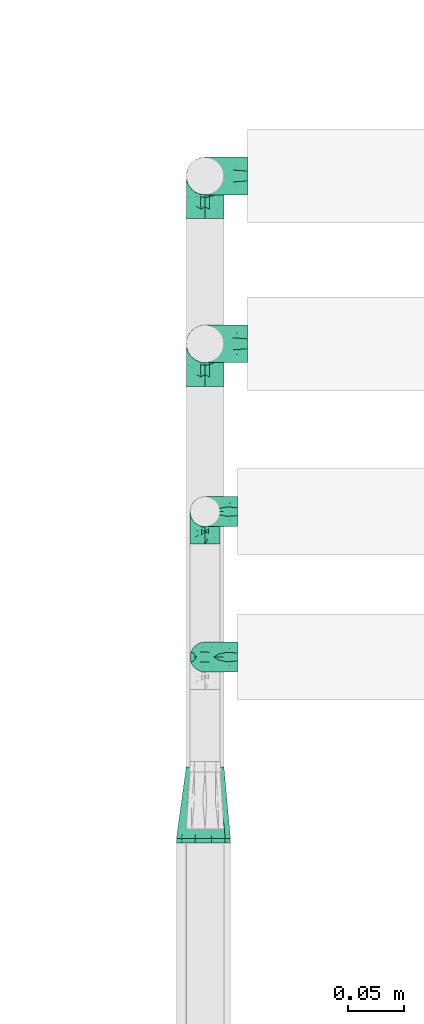
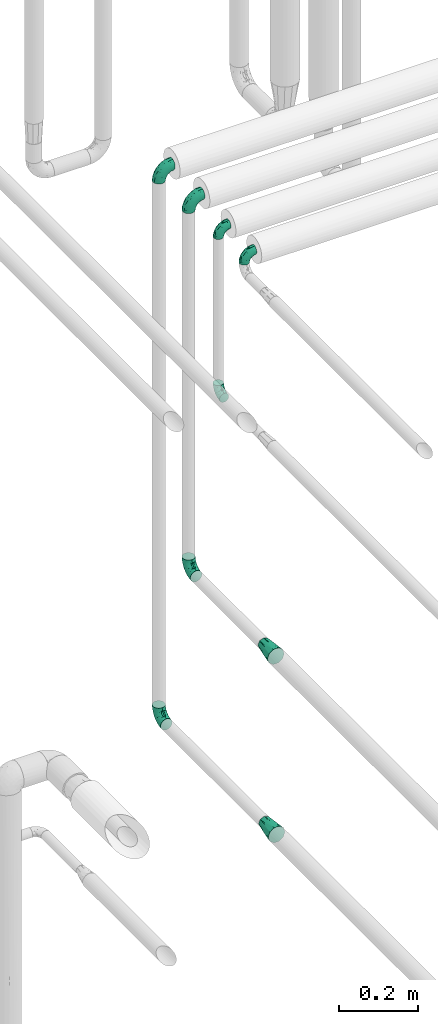
# One storey, part 736 of 827: 9 flow fittings.
"""IFC2X3 building model written with IfcOpenShell, lengths in millimetres."""

from ifc_helpers import new_model, entity, si_unit, converted_unit, derived_unit, direction, frame, origin, place, context, subcontext, project, spatial, faceted_brep, source, transform, mapped, material, type_object, type_shapes, element, save


model = new_model("IFC2X3")

# Units and contexts
model_context = context("Model", 3, precision=0.01, world=origin(), true_north=direction((6.12303176911189e-17, 1.0)))
body_context = subcontext(model_context, "Body", "Model", "MODEL_VIEW")
ifc_project = project(units=[si_unit("LENGTHUNIT", "METRE", prefix="MILLI"), si_unit("AREAUNIT", "SQUARE_METRE"), si_unit("VOLUMEUNIT", "CUBIC_METRE"), converted_unit("PLANEANGLEUNIT", "DEGREE", entity("IfcRatioMeasure", 0.0174532925199433), si_unit("PLANEANGLEUNIT", "RADIAN"), dimensions=[0, 0, 0, 0, 0, 0, 0]), si_unit("MASSUNIT", "GRAM", prefix="KILO"), derived_unit("MASSDENSITYUNIT", [(si_unit("MASSUNIT", "GRAM", prefix="KILO"), 1), (si_unit("LENGTHUNIT", "METRE"), -3)]), derived_unit("MOMENTOFINERTIAUNIT", [(si_unit("LENGTHUNIT", "METRE"), 4)]), si_unit("TIMEUNIT", "SECOND"), si_unit("FREQUENCYUNIT", "HERTZ"), si_unit("THERMODYNAMICTEMPERATUREUNIT", "DEGREE_CELSIUS"), derived_unit("THERMALTRANSMITTANCEUNIT", [(si_unit("MASSUNIT", "GRAM", prefix="KILO"), 1), (si_unit("THERMODYNAMICTEMPERATUREUNIT", "KELVIN"), -1), (si_unit("TIMEUNIT", "SECOND"), -3)]), derived_unit("VOLUMETRICFLOWRATEUNIT", [(si_unit("LENGTHUNIT", "METRE"), 3), (si_unit("TIMEUNIT", "SECOND"), -1)]), derived_unit("MASSFLOWRATEUNIT", [(si_unit("MASSUNIT", "GRAM", prefix="KILO"), 1), (si_unit("TIMEUNIT", "SECOND"), -1)]), derived_unit("ROTATIONALFREQUENCYUNIT", [(si_unit("TIMEUNIT", "SECOND"), -1)]), si_unit("ELECTRICCURRENTUNIT", "AMPERE"), si_unit("ELECTRICVOLTAGEUNIT", "VOLT"), si_unit("POWERUNIT", "WATT"), si_unit("FORCEUNIT", "NEWTON", prefix="KILO"), si_unit("ILLUMINANCEUNIT", "LUX"), si_unit("LUMINOUSFLUXUNIT", "LUMEN"), si_unit("LUMINOUSINTENSITYUNIT", "CANDELA"), derived_unit("USERDEFINED", [(si_unit("MASSUNIT", "GRAM", prefix="KILO"), -1), (si_unit("LENGTHUNIT", "METRE"), -2), (si_unit("TIMEUNIT", "SECOND"), 3), (si_unit("LUMINOUSFLUXUNIT", "LUMEN"), 1)]), derived_unit("LINEARVELOCITYUNIT", [(si_unit("LENGTHUNIT", "METRE"), 1), (si_unit("TIMEUNIT", "SECOND"), -1)]), si_unit("PRESSUREUNIT", "PASCAL"), derived_unit("USERDEFINED", [(si_unit("LENGTHUNIT", "METRE"), -2), (si_unit("MASSUNIT", "GRAM", prefix="KILO"), 1), (si_unit("TIMEUNIT", "SECOND"), -2)]), derived_unit("LINEARFORCEUNIT", [(si_unit("MASSUNIT", "GRAM", prefix="KILO"), 1), (si_unit("LENGTHUNIT", "METRE"), 1), (si_unit("TIMEUNIT", "SECOND"), -2), (si_unit("LENGTHUNIT", "METRE"), -1)]), derived_unit("PLANARFORCEUNIT", [(si_unit("MASSUNIT", "GRAM", prefix="KILO"), 1), (si_unit("LENGTHUNIT", "METRE"), 1), (si_unit("TIMEUNIT", "SECOND"), -2), (si_unit("LENGTHUNIT", "METRE"), -2)])], contexts=[model_context])

# Site, building, storey
site_placement = place(None, origin())
site = spatial("IfcSite", under=ifc_project, at=site_placement, CompositionType="ELEMENT")
building_placement = place(site_placement, origin())
building = spatial("IfcBuilding", under=site, at=building_placement, CompositionType="ELEMENT")
storey_placement = place(building_placement, frame((0.0, 0.0, 28200.0)))
storey = spatial("IfcBuildingStorey", under=building, at=storey_placement, Name="08", CompositionType="ELEMENT", Elevation=28200.0)

# Flow fittings
ifc_material = material()
pipe_fitting_type_1 = type_object("IfcPipeFittingType", Name="ADSK_1", PredefinedType="NOTDEFINED", material=ifc_material)
shared_shape_1 = source(origin(), body_context, "Body", "Brep", [
    faceted_brep([(-38.0, 0.0, -16.85), (-38.0, -4.36, -16.28), (-38.0, -8.43, -14.59), (-38.0, -11.91, -11.91), (-38.0, -14.59, -8.43), (-38.0, -16.28, -4.36), (-38.0, -16.85, 0.0), (-38.0, -16.28, 4.36), (-38.0, -14.59, 8.42), (-38.0, -11.91, 11.91), (-38.0, -8.43, 14.59), (-38.0, -4.36, 16.28), (-38.0, 0.0, 16.85), (-38.0, 4.36, 16.28), (-38.0, 8.42, 14.59), (-38.0, 11.91, 11.91), (-38.0, 14.59, 8.42), (-38.0, 16.28, 4.36), (-38.0, 16.85, 0.0), (-38.0, 16.28, -4.36), (-38.0, 14.59, -8.43), (-38.0, 11.91, -11.91), (-38.0, 8.42, -14.59), (-38.0, 4.36, -16.28), (-4.36, 38.0, -16.28), (-8.42, 38.0, -14.59), (-11.91, 38.0, -11.91), (-14.59, 38.0, -8.43), (-16.28, 38.0, -4.36), (-16.85, 38.0, 0.0), (-16.28, 38.0, 4.36), (-14.59, 38.0, 8.42), (-11.91, 38.0, 11.91), (-8.42, 38.0, 14.59), (-4.36, 38.0, 16.28), (0.0, 38.0, 16.85), (4.36, 38.0, 16.28), (8.43, 38.0, 14.59), (11.91, 38.0, 11.91), (14.59, 38.0, 8.42), (16.28, 38.0, 4.36), (16.85, 38.0, 0.0), (16.28, 38.0, -4.36), (14.59, 38.0, -8.43), (11.91, 38.0, -11.91), (8.43, 38.0, -14.59), (4.36, 38.0, -16.28), (0.0, 38.0, -16.85), (-27.9, -12.9, 9.54), (-27.5, -14.76, 0.0), (-16.53, -9.86, 8.66), (-24.93, -9.38, 12.63), (-29.29, -2.05, 16.58), (-26.82, 2.86, 16.81), (-25.18, -14.43, 5.37), (-4.54, 4.54, 14.04), (-15.36, -3.29, 14.19), (-7.56, -2.74, 10.9), (-28.06, -6.15, 15.21), (9.38, 24.93, 12.63), (-4.71, -4.42, 5.51), (-14.62, -10.99, 4.34), (-8.11, -6.73, 0.0), (-19.46, 0.42, 16.39), (-29.52, 14.25, 10.97), (-26.45, 18.14, 7.62), (-32.84, 15.94, 6.96), (-23.39, 16.22, 12.05), (-11.89, 8.53, 16.79), (-5.59, 13.42, 16.64), (-6.64, 18.62, 16.81), (-32.37, 10.35, 13.72), (-6.4, 32.67, 15.76), (-2.55, 28.48, 16.8), (6.81, 15.56, 11.71), (3.29, 15.36, 14.19), (-29.89, 18.0, 3.79), (-29.34, 6.81, 15.88), (-10.26, 4.27, 15.87), (-2.97, 11.0, 15.66), (2.45, 6.84, 10.65), (-1.8, -0.14, 8.44), (5.0, 5.5, 5.57), (-17.68, 27.4, 7.52), (14.43, 25.18, 5.37), (12.9, 27.9, 9.54), (9.86, 16.53, 8.66), (6.15, 28.06, 15.21), (-17.01, -12.67, 0.0), (2.05, 29.29, 16.58), (14.76, 27.5, 0.0), (10.99, 14.62, 4.34), (12.67, 17.01, 0.0), (-15.84, -6.82, 11.83), (-7.71, 25.61, 16.01), (-22.69, 22.69, 4.1), (-19.68, 27.42, 0.0), (-27.42, 19.68, 0.0), (-18.11, 29.67, 3.72), (-10.87, 29.33, 13.9), (-20.83, 21.64, 8.95), (-18.54, 20.86, 11.76), (-14.08, 30.19, 10.92), (-13.69, 20.27, 14.88), (-20.85, 7.92, 16.51), (-19.04, 4.79, 16.85), (-19.82, 12.26, 15.55), (-19.27, 16.43, 13.96), (-10.72, 19.56, 16.07), (-0.42, 19.46, 16.39), (-25.32, 12.08, 14.15), (-9.04, -6.0, 8.28), (-13.94, 13.94, 16.38), (0.78, -0.78, 0.0), (6.73, 8.11, 0.0), (-9.04, -6.0, -8.28), (-15.9, -7.04, -11.65), (-7.56, -2.74, -10.9), (6.15, 28.06, -15.21), (3.29, 15.36, -14.19), (-0.42, 19.46, -16.39), (-30.19, 14.08, -10.92), (-29.33, 10.87, -13.9), (-25.61, 7.71, -16.01), (-32.67, 6.4, -15.76), (-29.67, 18.11, -3.72), (-18.14, 26.45, -7.62), (-22.69, 22.69, -4.1), (-18.0, 29.89, -3.79), (-25.18, -14.43, -5.37), (-14.62, -10.99, -4.34), (-20.27, 13.69, -14.88), (-15.36, -3.29, -14.19), (-14.25, 29.52, -10.97), (-15.94, 32.84, -6.96), (-24.93, -9.38, -12.63), (-27.9, -12.9, -9.54), (6.81, 15.56, -11.71), (9.38, 24.93, -12.63), (-7.92, 20.85, -16.51), (-4.79, 19.04, -16.85), (-8.53, 11.89, -16.79), (-29.29, -2.05, -16.58), (-13.42, 5.59, -16.64), (-4.27, 10.26, -15.87), (-11.0, 2.97, -15.66), (-16.53, -9.86, -8.66), (-28.48, 2.55, -16.8), (-18.62, 6.64, -16.81), (10.99, 14.62, -4.34), (14.43, 25.18, -5.37), (-12.26, 19.82, -15.55), (-16.43, 19.27, -13.96), (12.9, 27.9, -9.54), (-10.35, 32.37, -13.72), (-6.81, 29.34, -15.88), (2.05, 29.29, -16.58), (-2.86, 26.82, -16.81), (-27.4, 17.68, -7.52), (5.0, 5.5, -5.57), (-16.22, 23.39, -12.05), (-28.06, -6.15, -15.21), (9.86, 16.53, -8.66), (-20.86, 18.54, -11.76), (-21.64, 20.83, -8.95), (-19.56, 10.72, -16.07), (-19.46, 0.42, -16.39), (-12.08, 25.32, -14.15), (-4.54, 4.54, -14.04), (-13.94, 13.94, -16.38), (2.45, 6.84, -10.65), (-4.71, -4.42, -5.51), (-1.8, -0.14, -8.44)], [[[0, 1, 2, 3, 4, 5, 6, 7, 8, 9, 10, 11, 12, 13, 14, 15, 16, 17, 18, 19, 20, 21, 22, 23]], [[24, 25, 26, 27, 28, 29, 30, 31, 32, 33, 34, 35, 36, 37, 38, 39, 40, 41, 42, 43, 44, 45, 46, 47]], [[8, 48, 9]], [[7, 6, 49]], [[48, 50, 51]], [[12, 52, 53]], [[8, 54, 48]], [[7, 54, 8]], [[55, 56, 57]], [[51, 10, 9]], [[51, 58, 10]], [[59, 38, 37]], [[60, 61, 62]], [[58, 56, 63]], [[64, 65, 66]], [[67, 65, 64]], [[68, 69, 70]], [[14, 71, 15]], [[11, 52, 12]], [[34, 72, 73]], [[12, 53, 13]], [[15, 64, 16]], [[74, 59, 75]], [[18, 17, 76]], [[66, 17, 16]], [[77, 13, 53]], [[13, 77, 14]], [[69, 78, 79]], [[80, 81, 82]], [[31, 30, 83]], [[84, 85, 86]], [[59, 87, 75]], [[61, 54, 88]], [[35, 89, 36]], [[84, 40, 39]], [[35, 34, 73]], [[90, 40, 84]], [[39, 38, 85]], [[10, 58, 11]], [[85, 84, 39]], [[91, 84, 86]], [[84, 92, 90]], [[87, 37, 36]], [[93, 56, 51]], [[94, 70, 73]], [[95, 96, 97]], [[84, 91, 92]], [[96, 98, 29]], [[33, 32, 99]], [[76, 95, 97]], [[100, 101, 83]], [[102, 99, 32]], [[65, 95, 76]], [[103, 94, 99]], [[95, 98, 96]], [[72, 99, 94]], [[72, 34, 33]], [[101, 99, 102]], [[7, 49, 54]], [[87, 59, 37]], [[104, 105, 68]], [[106, 103, 107]], [[106, 77, 104]], [[32, 31, 102]], [[94, 103, 108]], [[94, 108, 70]], [[89, 73, 109]], [[71, 64, 15]], [[110, 107, 67]], [[50, 48, 54]], [[51, 9, 48]], [[56, 58, 51]], [[88, 54, 49]], [[52, 58, 63]], [[50, 111, 93]], [[56, 55, 78]], [[38, 59, 85]], [[86, 85, 59]], [[89, 87, 36]], [[41, 40, 90]], [[109, 79, 75]], [[109, 75, 87]], [[75, 55, 80]], [[104, 77, 53]], [[71, 77, 110]], [[31, 83, 102]], [[101, 102, 83]], [[99, 101, 103]], [[106, 107, 110]], [[68, 70, 112]], [[109, 73, 70]], [[68, 112, 104]], [[68, 63, 78]], [[57, 93, 111]], [[80, 55, 57]], [[61, 50, 54]], [[80, 82, 86]], [[81, 57, 111]], [[74, 86, 59]], [[60, 113, 82]], [[82, 114, 91]], [[100, 95, 65]], [[98, 95, 83]], [[73, 89, 35]], [[87, 89, 109]], [[58, 52, 11]], [[53, 52, 63]], [[104, 53, 105]], [[106, 104, 112]], [[18, 76, 97]], [[76, 17, 66]], [[103, 106, 112]], [[77, 106, 110]], [[103, 101, 107]], [[67, 107, 101]], [[67, 101, 100]], [[110, 67, 64]], [[83, 30, 98]], [[29, 98, 30]], [[53, 63, 105]], [[63, 68, 105]], [[56, 78, 63]], [[79, 78, 55]], [[75, 79, 55]], [[69, 79, 109]], [[70, 69, 109]], [[78, 69, 68]], [[62, 113, 60]], [[111, 61, 60]], [[61, 88, 62]], [[86, 82, 91]], [[77, 71, 14]], [[114, 82, 113]], [[114, 92, 91]], [[64, 71, 110]], [[99, 72, 33]], [[73, 72, 94]], [[64, 66, 16]], [[76, 66, 65]], [[95, 100, 83]], [[67, 100, 65]], [[75, 80, 74]], [[80, 86, 74]], [[103, 112, 108]], [[70, 108, 112]], [[50, 93, 51]], [[57, 56, 93]], [[61, 111, 50]], [[81, 111, 60]], [[82, 81, 60]], [[80, 57, 81]], [[115, 116, 117]], [[118, 119, 120]], [[121, 122, 21]], [[123, 124, 122]], [[97, 125, 18]], [[126, 127, 128]], [[127, 97, 96]], [[129, 130, 88]], [[123, 122, 131]], [[116, 132, 117]], [[133, 126, 134]], [[22, 124, 23]], [[3, 135, 136]], [[137, 119, 138]], [[129, 88, 49]], [[139, 140, 141]], [[4, 3, 136]], [[45, 118, 46]], [[142, 1, 0]], [[143, 144, 145]], [[4, 129, 5]], [[129, 136, 146]], [[147, 0, 23]], [[22, 21, 122]], [[127, 125, 97]], [[123, 148, 147]], [[96, 128, 127]], [[149, 150, 92]], [[29, 28, 128]], [[151, 131, 152]], [[26, 133, 27]], [[153, 44, 43]], [[135, 3, 2]], [[26, 25, 154]], [[155, 25, 24]], [[47, 156, 157]], [[47, 46, 156]], [[20, 19, 158]], [[159, 149, 114]], [[126, 133, 160]], [[141, 143, 148]], [[45, 138, 118]], [[161, 135, 2]], [[155, 24, 157]], [[23, 124, 147]], [[115, 146, 116]], [[44, 153, 138]], [[138, 45, 44]], [[153, 162, 138]], [[161, 2, 1]], [[41, 90, 42]], [[130, 129, 146]], [[49, 5, 129]], [[42, 150, 43]], [[163, 122, 121]], [[47, 157, 24]], [[135, 161, 132]], [[134, 28, 27]], [[42, 90, 150]], [[164, 163, 158]], [[151, 155, 139]], [[21, 20, 121]], [[123, 131, 165]], [[123, 165, 148]], [[142, 147, 166]], [[154, 133, 26]], [[167, 152, 160]], [[146, 136, 135]], [[6, 5, 49]], [[129, 4, 136]], [[142, 161, 1]], [[166, 145, 132]], [[166, 132, 161]], [[132, 168, 117]], [[43, 150, 153]], [[92, 150, 90]], [[162, 153, 150]], [[119, 118, 138]], [[156, 118, 120]], [[137, 138, 162]], [[119, 168, 144]], [[139, 155, 157]], [[154, 155, 167]], [[20, 158, 121]], [[163, 121, 158]], [[122, 163, 131]], [[151, 152, 167]], [[141, 148, 169]], [[166, 147, 148]], [[141, 169, 139]], [[141, 120, 144]], [[168, 170, 117]], [[159, 171, 172]], [[115, 172, 171]], [[171, 62, 130]], [[119, 170, 168]], [[170, 162, 159]], [[149, 162, 150]], [[113, 171, 159]], [[164, 127, 126]], [[125, 127, 158]], [[147, 142, 0]], [[161, 142, 166]], [[118, 156, 46]], [[157, 156, 120]], [[139, 157, 140]], [[151, 139, 169]], [[29, 128, 96]], [[128, 28, 134]], [[131, 151, 169]], [[155, 151, 167]], [[131, 163, 152]], [[160, 152, 163]], [[160, 163, 164]], [[167, 160, 133]], [[158, 19, 125]], [[18, 125, 19]], [[157, 120, 140]], [[120, 141, 140]], [[119, 144, 120]], [[145, 144, 168]], [[132, 145, 168]], [[143, 145, 166]], [[148, 143, 166]], [[144, 143, 141]], [[115, 130, 146]], [[114, 113, 159]], [[62, 171, 113]], [[62, 88, 130]], [[159, 162, 149]], [[149, 92, 114]], [[155, 154, 25]], [[133, 154, 167]], [[122, 124, 22]], [[147, 124, 123]], [[133, 134, 27]], [[128, 134, 126]], [[127, 164, 158]], [[160, 164, 126]], [[162, 170, 137]], [[170, 119, 137]], [[131, 169, 165]], [[148, 165, 169]], [[146, 135, 116]], [[132, 116, 135]], [[172, 115, 117]], [[130, 115, 171]], [[117, 170, 172]], [[159, 172, 170]]]),
])
type_shapes(pipe_fitting_type_1, [shared_shape_1])
for number, where, z_axis, x_axis, name in (
    (1, (16128.05, 13250.0, 2400.0), (0.0, -1.0, 0.0), (-1.0, 0.0, 0.0), "ADSK_1"),
    (2, (16128.05, 13250.0, 712.06), (-1.0, 0.0, 0.0), (0.0, 0.0, -1.0), "ADSK_1"),
    (3, (16128.05, 13100.0, 2400.0), (0.0, -1.0, 0.0), (-1.0, 0.0, 0.0), "ADSK_1"),
    (4, (16128.05, 13100.0, 1258.33), (-1.0, 0.0, 0.0), (0.0, 0.0, -1.0), "ADSK_1"),
):
    element("IfcFlowFitting", number, at=place(storey_placement, frame(where, z_axis=z_axis, x_axis=x_axis)), inside=storey, type_object=pipe_fitting_type_1, material=ifc_material, Name=name, ObjectType="ADSK_1", context=body_context, shape_type="MappedRepresentation", body=[
        mapped(shared_shape_1, transform((0.0, 0.0, 0.0), scale=1.0)),
    ])
pipe_fitting_type_2 = type_object("IfcPipeFittingType", Name="ADSK_1", PredefinedType="NOTDEFINED", material=ifc_material)
shared_shape_2 = source(origin(), body_context, "Body", "Brep", [
    faceted_brep([(-29.1, 0.0, -13.45), (-29.1, -3.48, -12.99), (-29.1, -6.73, -11.65), (-29.1, -9.51, -9.51), (-29.1, -11.65, -6.73), (-29.1, -12.99, -3.48), (-29.1, -13.45, 0.0), (-29.1, -12.99, 3.48), (-29.1, -11.65, 6.72), (-29.1, -9.51, 9.51), (-29.1, -6.73, 11.65), (-29.1, -3.48, 12.99), (-29.1, 0.0, 13.45), (-29.1, 3.48, 12.99), (-29.1, 6.72, 11.65), (-29.1, 9.51, 9.51), (-29.1, 11.65, 6.72), (-29.1, 12.99, 3.48), (-29.1, 13.45, 0.0), (-29.1, 12.99, -3.48), (-29.1, 11.65, -6.73), (-29.1, 9.51, -9.51), (-29.1, 6.72, -11.65), (-29.1, 3.48, -12.99), (-3.48, 29.1, -12.99), (-6.72, 29.1, -11.65), (-9.51, 29.1, -9.51), (-11.65, 29.1, -6.73), (-12.99, 29.1, -3.48), (-13.45, 29.1, 0.0), (-12.99, 29.1, 3.48), (-11.65, 29.1, 6.72), (-9.51, 29.1, 9.51), (-6.72, 29.1, 11.65), (-3.48, 29.1, 12.99), (0.0, 29.1, 13.45), (3.48, 29.1, 12.99), (6.73, 29.1, 11.65), (9.51, 29.1, 9.51), (11.65, 29.1, 6.72), (12.99, 29.1, 3.48), (13.45, 29.1, 0.0), (12.99, 29.1, -3.48), (11.65, 29.1, -6.73), (9.51, 29.1, -9.51), (6.73, 29.1, -11.65), (3.48, 29.1, -12.99), (0.0, 29.1, -13.45), (-19.62, -11.66, 4.28), (-21.41, -10.36, 7.6), (-16.26, -10.01, 0.0), (-12.48, -9.76, 2.75), (-10.66, 15.6, 11.91), (-15.27, 9.55, 12.42), (-10.71, 10.71, 13.09), (-0.04, 0.04, 0.0), (0.49, -0.45, 4.38), (-3.67, -4.15, 4.26), (-22.68, -11.73, 0.0), (-21.45, -4.97, 12.13), (-11.59, -2.84, 11.28), (-14.77, 0.17, 13.07), (-19.08, -7.58, 10.06), (-22.36, -1.69, 13.23), (-20.49, 2.21, 13.42), (-7.82, -7.75, 0.0), (-5.53, -2.55, 8.58), (-1.33, -0.87, 6.53), (-1.15, 1.15, 8.49), (-22.46, 5.38, 12.69), (-14.04, 21.05, 6.04), (-3.19, 3.19, 11.14), (-5.08, 25.05, 12.59), (-1.97, 21.79, 13.41), (-22.68, 11.31, 8.78), (-18.16, 12.64, 9.68), (-20.46, 14.33, 6.11), (-4.13, 10.11, 13.26), (-7.66, 3.08, 12.63), (-2.02, 8.24, 12.45), (-24.91, 8.22, 10.95), (-5.08, 14.28, 13.42), (-8.96, 6.48, 13.4), (-19.7, 16.14, 3.1), (-18.03, 18.03, 0.0), (-23.05, 15.96, 0.0), (-25.26, 12.69, 5.56), (4.97, 21.45, 12.13), (7.58, 19.08, 10.06), (1.69, 22.36, 13.23), (10.36, 21.41, 7.6), (8.11, 12.69, 6.86), (11.66, 19.62, 4.28), (-6.03, 19.65, 12.79), (9.76, 12.48, 2.75), (10.01, 16.26, 0.0), (-14.58, 16.06, 9.44), (-11.19, 23.14, 8.74), (-16.29, 16.8, 7.24), (-11.99, -5.68, 9.36), (-15.42, 20.78, 3.08), (5.79, 12.02, 9.27), (2.84, 11.59, 11.28), (2.55, 5.53, 8.58), (-15.74, 23.57, 0.0), (-15.96, 23.05, 0.0), (-24.62, 13.88, 2.39), (-8.61, 22.49, 11.12), (-14.98, 12.8, 11.14), (11.73, 22.68, 0.0), (-12.69, -8.11, 6.86), (7.75, 7.82, 0.0), (-15.98, 6.12, 13.19), (-14.48, 3.64, 13.45), (-19.6, 9.46, 11.31), (-8.3, 15.02, 12.85), (-0.17, 14.77, 13.07), (-6.9, -5.2, 6.52), (7.5, 8.93, 4.46), (5.22, 6.95, 6.56), (-8.85, -7.47, 4.42), (3.86, 3.93, 0.0), (4.18, 3.75, 4.31), (-23.57, 15.74, 0.0), (-3.93, -3.86, 0.0), (-21.79, 1.97, -13.41), (-11.31, 22.68, -8.78), (-14.33, 20.46, -6.11), (-12.69, 25.26, -5.56), (4.97, 21.45, -12.13), (2.84, 11.59, -11.28), (-0.17, 14.77, -13.07), (-25.05, 5.08, -12.59), (-16.8, 16.29, -7.24), (-20.78, 15.42, -3.08), (-16.14, 19.7, -3.1), (-12.02, -5.79, -9.27), (-11.59, -2.84, -11.28), (-5.53, -2.55, -8.58), (-23.14, 11.19, -8.74), (-22.49, 8.61, -11.12), (-1.33, -0.87, -6.53), (-3.67, -4.15, -4.26), (-6.9, -5.2, -6.52), (-19.65, 6.03, -12.79), (-15.6, 10.66, -11.91), (-14.28, 5.08, -13.42), (-10.71, 10.71, -13.09), (-6.48, 8.96, -13.4), (-19.62, -11.66, -4.28), (-21.41, -10.36, -7.6), (-12.48, -9.76, -2.75), (11.66, 19.62, -4.28), (-12.69, -8.11, -6.86), (-22.36, -1.69, -13.23), (-16.06, 14.58, -9.44), (5.68, 11.99, -9.36), (7.58, 19.08, -10.06), (-19.08, -7.58, -10.06), (-21.45, -4.97, -12.13), (-9.55, 15.27, -12.42), (-12.8, 14.98, -11.14), (-8.22, 24.91, -10.95), (10.36, 21.41, -7.6), (-5.38, 22.46, -12.69), (1.69, 22.36, -13.23), (-2.21, 20.49, -13.42), (-12.64, 18.16, -9.68), (-21.05, 14.04, -6.04), (9.76, 12.48, -2.75), (-10.11, 4.13, -13.26), (-3.08, 7.66, -12.63), (-8.24, 2.02, -12.45), (-13.88, 24.62, -2.39), (8.11, 12.69, -6.86), (-6.12, 15.98, -13.19), (-3.64, 14.48, -13.45), (-9.46, 19.6, -11.31), (-15.02, 8.3, -12.85), (-14.77, 0.17, -13.07), (-3.19, 3.19, -11.14), (5.22, 6.95, -6.56), (2.55, 5.53, -8.58), (0.49, -0.45, -4.38), (4.18, 3.75, -4.31), (-8.85, -7.47, -4.42), (-1.15, 1.15, -8.49), (7.5, 8.93, -4.46)], [[[0, 1, 2, 3, 4, 5, 6, 7, 8, 9, 10, 11, 12, 13, 14, 15, 16, 17, 18, 19, 20, 21, 22, 23]], [[24, 25, 26, 27, 28, 29, 30, 31, 32, 33, 34, 35, 36, 37, 38, 39, 40, 41, 42, 43, 44, 45, 46, 47]], [[48, 49, 8]], [[48, 50, 51]], [[52, 53, 54]], [[55, 56, 57]], [[49, 9, 8]], [[58, 48, 7]], [[59, 60, 61]], [[62, 10, 9]], [[62, 59, 10]], [[12, 63, 64]], [[51, 50, 65]], [[66, 67, 68]], [[12, 11, 63]], [[69, 14, 13]], [[31, 30, 70]], [[66, 71, 60]], [[34, 72, 73]], [[74, 75, 76]], [[77, 78, 79]], [[14, 80, 15]], [[16, 15, 74]], [[81, 54, 82]], [[83, 84, 85]], [[74, 76, 86]], [[37, 87, 88]], [[88, 38, 37]], [[36, 35, 89]], [[90, 91, 92]], [[93, 81, 73]], [[35, 34, 73]], [[10, 59, 11]], [[92, 94, 95]], [[96, 97, 98]], [[90, 92, 39]], [[99, 60, 62]], [[40, 39, 92]], [[87, 37, 36]], [[100, 84, 83]], [[50, 48, 58]], [[100, 83, 98]], [[101, 102, 103]], [[104, 105, 84, 100, 29]], [[48, 8, 7]], [[86, 17, 16]], [[106, 18, 17]], [[32, 97, 107]], [[53, 52, 108]], [[52, 93, 107]], [[97, 96, 107]], [[72, 107, 93]], [[72, 34, 33]], [[92, 109, 40]], [[33, 32, 107]], [[69, 13, 64]], [[88, 87, 102]], [[12, 64, 13]], [[49, 110, 62]], [[39, 38, 90]], [[95, 94, 111]], [[112, 113, 82]], [[53, 69, 112]], [[80, 74, 15]], [[114, 108, 75]], [[32, 31, 97]], [[115, 52, 54]], [[93, 115, 81]], [[89, 73, 116]], [[106, 76, 83]], [[106, 83, 85]], [[83, 76, 98]], [[100, 30, 29]], [[60, 59, 62]], [[63, 59, 61]], [[110, 117, 99]], [[60, 71, 78]], [[89, 87, 36]], [[116, 79, 102]], [[116, 102, 87]], [[102, 71, 103]], [[110, 49, 48]], [[62, 9, 49]], [[38, 88, 90]], [[91, 90, 88]], [[112, 69, 64]], [[80, 69, 114]], [[111, 94, 118]], [[119, 101, 103]], [[117, 66, 99]], [[117, 120, 57]], [[119, 91, 101]], [[66, 68, 71]], [[66, 117, 67]], [[121, 111, 122, 55]], [[56, 55, 122]], [[31, 70, 97]], [[97, 70, 98]], [[107, 96, 52]], [[53, 108, 114]], [[112, 82, 54]], [[116, 73, 81]], [[78, 82, 61]], [[81, 82, 77]], [[73, 89, 35]], [[87, 89, 116]], [[59, 63, 11]], [[64, 63, 61]], [[112, 64, 113]], [[53, 112, 54]], [[7, 6, 58]], [[109, 92, 95]], [[109, 41, 40]], [[69, 53, 114]], [[52, 96, 108]], [[75, 108, 96]], [[75, 96, 98]], [[114, 75, 74]], [[64, 61, 113]], [[61, 82, 113]], [[91, 88, 101]], [[110, 48, 51]], [[92, 91, 94]], [[91, 119, 118]], [[106, 85, 123, 18]], [[106, 17, 86]], [[60, 78, 61]], [[79, 78, 71]], [[102, 79, 71]], [[77, 79, 116]], [[81, 77, 116]], [[78, 77, 82]], [[69, 80, 14]], [[74, 80, 114]], [[74, 86, 16]], [[106, 86, 76]], [[107, 72, 33]], [[73, 72, 93]], [[98, 70, 100]], [[75, 98, 76]], [[30, 100, 70]], [[110, 99, 62]], [[66, 60, 99]], [[120, 110, 51]], [[67, 117, 57]], [[57, 56, 67]], [[67, 122, 119]], [[110, 120, 117]], [[65, 120, 51]], [[57, 65, 124, 55]], [[122, 67, 56]], [[67, 103, 68]], [[71, 68, 103]], [[65, 57, 120]], [[102, 101, 88]], [[67, 119, 103]], [[118, 119, 122]], [[118, 122, 111]], [[91, 118, 94]], [[81, 115, 54]], [[93, 52, 115]], [[23, 125, 0]], [[126, 127, 128]], [[129, 130, 131]], [[23, 22, 132]], [[133, 134, 135]], [[136, 137, 138]], [[21, 139, 140]], [[141, 142, 143]], [[144, 140, 145]], [[143, 136, 138]], [[146, 147, 148]], [[144, 132, 140]], [[5, 4, 149]], [[4, 3, 150]], [[45, 129, 46]], [[151, 50, 149]], [[152, 43, 42]], [[42, 41, 109]], [[150, 149, 4]], [[153, 149, 150]], [[154, 1, 0]], [[139, 155, 140]], [[156, 130, 157]], [[149, 58, 5]], [[18, 123, 85, 84, 134]], [[158, 159, 137]], [[84, 105, 135]], [[160, 145, 161]], [[143, 153, 136]], [[27, 26, 126]], [[25, 162, 26]], [[152, 163, 43]], [[25, 24, 164]], [[47, 165, 166]], [[158, 3, 2]], [[167, 127, 126]], [[20, 19, 168]], [[47, 46, 165]], [[44, 157, 45]], [[23, 132, 125]], [[44, 43, 163]], [[158, 2, 159]], [[47, 166, 24]], [[129, 45, 157]], [[164, 24, 166]], [[134, 84, 135]], [[95, 169, 152]], [[22, 21, 140]], [[144, 146, 125]], [[109, 152, 42]], [[95, 152, 109]], [[170, 171, 172]], [[155, 139, 133]], [[28, 27, 128]], [[159, 2, 1]], [[173, 29, 28]], [[50, 151, 65]], [[169, 95, 111]], [[163, 174, 157]], [[175, 176, 148]], [[160, 164, 175]], [[162, 126, 26]], [[177, 161, 167]], [[21, 20, 139]], [[144, 145, 178]], [[144, 178, 146]], [[154, 125, 179]], [[173, 127, 135]], [[173, 135, 105]], [[135, 127, 133]], [[134, 19, 18]], [[154, 159, 1]], [[179, 172, 137]], [[179, 137, 159]], [[137, 180, 138]], [[130, 129, 157]], [[165, 129, 131]], [[174, 181, 156]], [[130, 180, 171]], [[3, 158, 150]], [[153, 150, 158]], [[174, 163, 152]], [[157, 44, 163]], [[175, 164, 166]], [[162, 164, 177]], [[130, 182, 180]], [[181, 141, 182]], [[55, 183, 184]], [[65, 151, 185]], [[183, 55, 142]], [[156, 181, 182]], [[180, 182, 186]], [[181, 187, 184]], [[65, 142, 55, 124]], [[20, 168, 139]], [[139, 168, 133]], [[140, 155, 145]], [[160, 161, 177]], [[175, 148, 147]], [[179, 125, 146]], [[171, 148, 131]], [[146, 148, 170]], [[125, 154, 0]], [[159, 154, 179]], [[129, 165, 46]], [[166, 165, 131]], [[175, 166, 176]], [[160, 175, 147]], [[58, 149, 50]], [[58, 6, 5]], [[145, 160, 147]], [[164, 160, 177]], [[145, 155, 161]], [[167, 161, 155]], [[167, 155, 133]], [[177, 167, 126]], [[166, 131, 176]], [[131, 148, 176]], [[149, 153, 151]], [[153, 143, 185]], [[145, 147, 178]], [[174, 152, 169]], [[173, 105, 104, 29]], [[173, 28, 128]], [[130, 171, 131]], [[172, 171, 180]], [[137, 172, 180]], [[170, 172, 179]], [[146, 170, 179]], [[171, 170, 148]], [[164, 162, 25]], [[126, 162, 177]], [[126, 128, 27]], [[173, 128, 127]], [[140, 132, 22]], [[125, 132, 144]], [[133, 168, 134]], [[167, 133, 127]], [[19, 134, 168]], [[153, 158, 136]], [[137, 136, 158]], [[141, 143, 138]], [[185, 143, 142]], [[186, 141, 138]], [[183, 142, 141]], [[185, 142, 65]], [[153, 185, 151]], [[180, 186, 138]], [[182, 141, 186]], [[141, 184, 183]], [[184, 111, 121, 55]], [[174, 156, 157]], [[182, 130, 156]], [[187, 174, 169]], [[141, 181, 184]], [[174, 187, 181]], [[111, 187, 169]], [[111, 184, 187]], [[146, 178, 147]]]),
])
type_shapes(pipe_fitting_type_2, [shared_shape_2])
for number, where, z_axis, x_axis, name in (
    (5, (16128.05, 12950.0, 2400.0), (0.0, -1.0, 0.0), (-1.0, 0.0, 0.0), "ADSK_1"),
    (6, (16128.05, 12950.0, 1892.6), (-1.0, 0.0, 0.0), (0.0, 0.0, -1.0), "ADSK_1"),
    (7, (16128.05, 12820.0, 2400.0), (0.0, -1.0, 0.0), (-1.0, 0.0, 0.0), "ADSK_1"),
):
    element("IfcFlowFitting", number, at=place(storey_placement, frame(where, z_axis=z_axis, x_axis=x_axis)), inside=storey, type_object=pipe_fitting_type_2, material=ifc_material, Name=name, ObjectType="ADSK_1", context=body_context, shape_type="MappedRepresentation", body=[
        mapped(shared_shape_2, transform((0.0, 0.0, 0.0), scale=1.0)),
    ])
pipe_fitting_type_3 = type_object("IfcPipeFittingType", Name="ADSK_1", PredefinedType="NOTDEFINED", material=ifc_material)
shared_shape_3 = source(origin(), body_context, "Body", "Brep", [
    faceted_brep([(64.0, 22.65, 0.0), (64.0, 20.34, 7.1), (64.0, 18.04, 14.2), (64.0, 12.0, 18.58), (64.0, 5.96, 22.97), (64.0, -1.5, 22.97), (64.0, -8.96, 22.97), (64.0, -15.0, 18.58), (64.0, -21.04, 14.2), (64.0, -23.35, 7.1), (64.0, -25.65, 0.0), (64.0, -23.35, -7.1), (64.0, -21.04, -14.2), (64.0, -15.0, -18.58), (64.0, -8.96, -22.97), (64.0, -1.5, -22.97), (64.0, 5.96, -22.97), (64.0, 12.0, -18.58), (64.0, 18.04, -14.2), (64.0, 20.34, -7.1), (0.0, -11.91, -11.91), (0.0, -13.15, -8.94), (0.0, -14.38, -5.96), (0.0, -15.62, -2.98), (0.0, -16.85, 0.0), (0.0, -15.63, 2.94), (0.0, -14.38, 5.96), (0.0, -13.15, 8.94), (0.0, -11.91, 11.91), (0.0, -8.94, 13.15), (0.0, -5.96, 14.38), (0.0, -2.98, 15.62), (0.0, 0.0, 16.85), (0.0, 2.98, 15.62), (0.0, 5.96, 14.38), (0.0, 8.94, 13.15), (0.0, 11.91, 11.91), (0.0, 13.15, 8.94), (0.0, 14.38, 5.96), (0.0, 15.62, 2.98), (0.0, 16.85, 0.0), (0.0, 15.63, -2.94), (0.0, 14.38, -5.96), (0.0, 13.15, -8.94), (0.0, 11.91, -11.91), (0.0, 8.94, -13.15), (0.0, 5.96, -14.38), (0.0, 2.98, -15.62), (0.0, 0.0, -16.85), (0.0, -2.98, -15.62), (0.0, -5.96, -14.38), (0.0, -8.94, -13.15), (31.52, -16.38, -13.17), (29.6, -20.12, -5.62), (32.0, -21.25, 0.0), (31.01, 16.96, -10.14), (29.99, 18.7, -5.86), (27.99, -13.26, -15.59), (33.97, -19.07, -9.77), (29.6, -6.31, -19.43), (32.0, -2.27, -20.44), (29.6, 4.92, -19.43), (33.97, 8.97, -18.28), (31.99, 19.75, 0.0), (26.84, 11.66, -15.67), (33.97, -10.57, -18.28), (25.51, 1.42, -19.66), (33.59, 14.61, -13.8), (31.52, 14.9, 13.17), (29.6, 18.74, 5.62), (31.01, -18.42, 10.14), (29.99, -20.11, 5.86), (27.99, 11.94, 15.59), (33.97, 17.48, 9.77), (29.6, 4.92, 19.43), (32.0, 0.77, 20.44), (29.6, -6.31, 19.43), (33.97, -10.57, 18.28), (26.84, -12.92, 15.67), (33.97, 8.97, 18.28), (25.51, -2.62, 19.66), (33.59, -16.19, 13.8)], [[[0, 1, 2, 3, 4, 5, 6, 7, 8, 9, 10, 11, 12, 13, 14, 15, 16, 17, 18, 19]], [[20, 21, 22, 23, 24, 25, 26, 27, 28, 29, 30, 31, 32, 33, 34, 35, 36, 37, 38, 39, 40, 41, 42, 43, 44, 45, 46, 47, 48, 49, 50, 51]], [[20, 52, 21]], [[23, 53, 54]], [[55, 42, 56]], [[52, 57, 13]], [[21, 58, 22]], [[53, 22, 58]], [[51, 57, 20]], [[53, 58, 11]], [[52, 13, 12]], [[59, 60, 14]], [[61, 46, 62]], [[63, 56, 41]], [[17, 16, 62]], [[56, 42, 41]], [[10, 53, 11]], [[12, 58, 52]], [[64, 17, 62]], [[65, 59, 14]], [[12, 11, 58]], [[60, 66, 15]], [[48, 47, 66]], [[53, 10, 54]], [[21, 52, 58]], [[23, 22, 53]], [[65, 51, 50]], [[51, 65, 57]], [[59, 65, 50]], [[14, 13, 65]], [[59, 50, 49]], [[59, 49, 60]], [[13, 57, 65]], [[60, 49, 48]], [[20, 57, 52]], [[55, 56, 19]], [[19, 56, 0]], [[0, 56, 63]], [[41, 40, 63]], [[55, 19, 18]], [[67, 55, 18]], [[67, 43, 55]], [[18, 17, 67]], [[45, 64, 62]], [[45, 62, 46]], [[67, 64, 44]], [[61, 62, 16]], [[66, 16, 15]], [[66, 47, 61]], [[43, 67, 44]], [[47, 46, 61]], [[43, 42, 55]], [[24, 23, 54]], [[14, 60, 15]], [[66, 61, 16]], [[48, 66, 60]], [[44, 64, 45]], [[17, 64, 67]], [[36, 68, 37]], [[39, 69, 63]], [[70, 26, 71]], [[68, 72, 3]], [[37, 73, 38]], [[69, 38, 73]], [[35, 72, 36]], [[69, 73, 1]], [[68, 3, 2]], [[74, 75, 4]], [[76, 30, 77]], [[54, 71, 25]], [[7, 6, 77]], [[71, 26, 25]], [[0, 69, 1]], [[2, 73, 68]], [[78, 7, 77]], [[79, 74, 4]], [[2, 1, 73]], [[75, 80, 5]], [[32, 31, 80]], [[69, 0, 63]], [[37, 68, 73]], [[39, 38, 69]], [[79, 35, 34]], [[35, 79, 72]], [[74, 79, 34]], [[4, 3, 79]], [[74, 34, 33]], [[74, 33, 75]], [[3, 72, 79]], [[75, 33, 32]], [[36, 72, 68]], [[70, 71, 9]], [[9, 71, 10]], [[10, 71, 54]], [[25, 24, 54]], [[70, 9, 8]], [[81, 70, 8]], [[81, 27, 70]], [[8, 7, 81]], [[29, 78, 77]], [[29, 77, 30]], [[81, 78, 28]], [[76, 77, 6]], [[80, 6, 5]], [[80, 31, 76]], [[27, 81, 28]], [[31, 30, 76]], [[27, 26, 70]], [[40, 39, 63]], [[4, 75, 5]], [[80, 76, 6]], [[32, 80, 75]], [[28, 78, 29]], [[7, 78, 81]]]),
])
type_shapes(pipe_fitting_type_3, [shared_shape_3])
for number, where, z_axis, x_axis, name in (
    (8, (16128.05, 12721.6, 1258.33), (0.0, 0.0, 1.0), (0.0, -1.0, 0.0), "ADSK_1"),
    (9, (16128.05, 12717.91, 712.06), (0.0, 0.0, 1.0), (0.0, -1.0, 0.0), "ADSK_1"),
):
    element("IfcFlowFitting", number, at=place(storey_placement, frame(where, z_axis=z_axis, x_axis=x_axis)), inside=storey, type_object=pipe_fitting_type_3, material=ifc_material, Name=name, ObjectType="ADSK_1", context=body_context, shape_type="MappedRepresentation", body=[
        mapped(shared_shape_3, transform((0.0, 0.0, 0.0), scale=1.0)),
    ])

save(model, "model.ifc")
